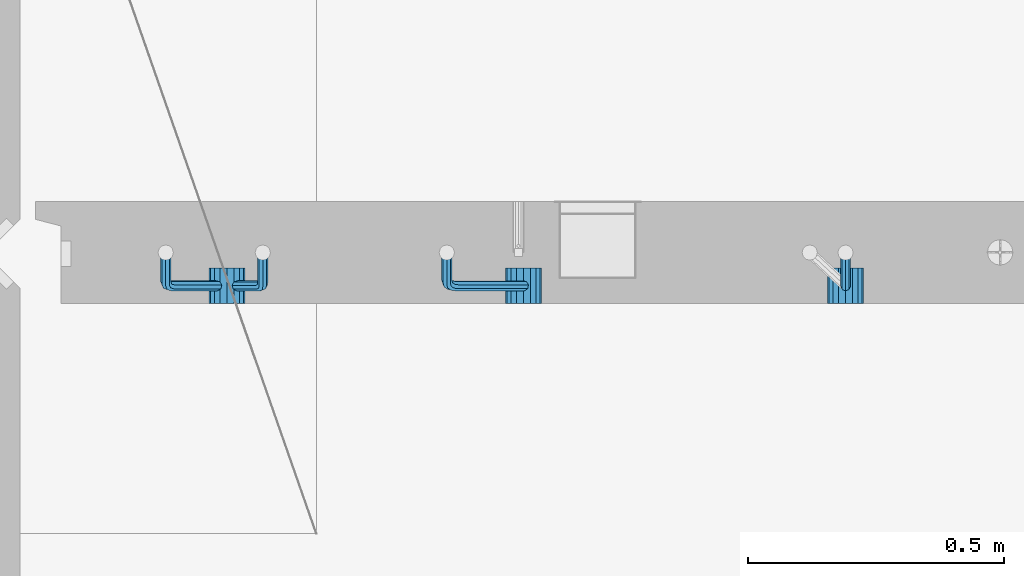
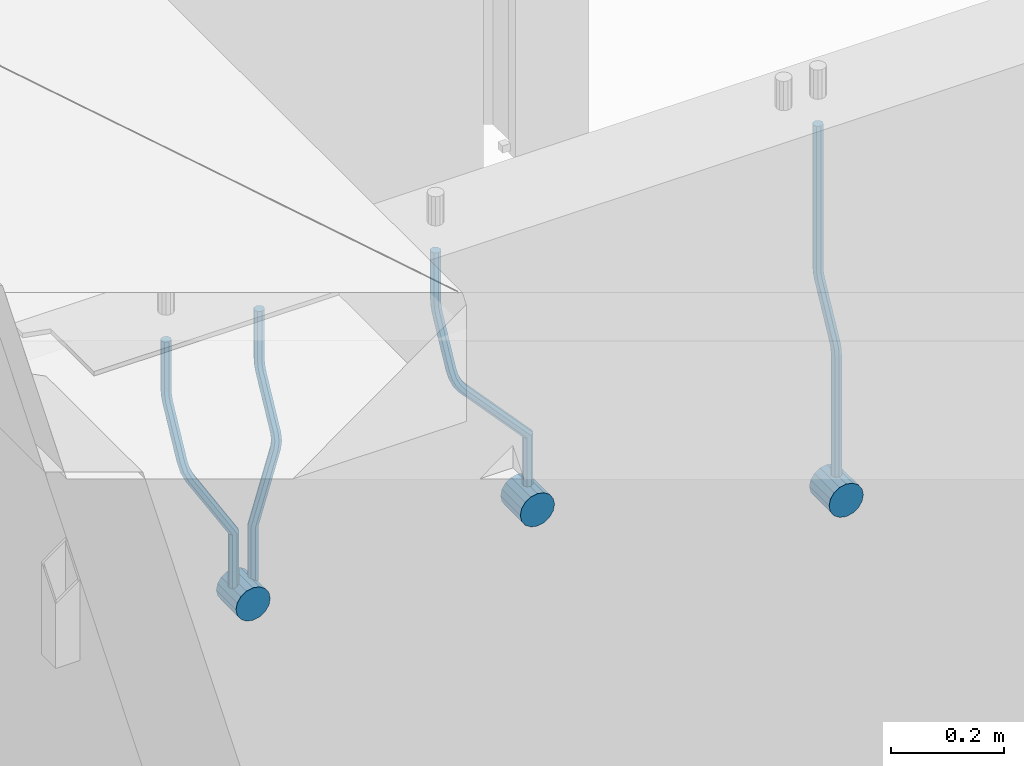
# One storey, part 148 of 334: 7 beams, 1 element without a shape of its own.
"""IFC2X3 building model written with IfcOpenShell, lengths in millimetres."""

import ifcopenshell
import ifcopenshell.guid

model = None  # the IFC model being written
_history = None  # IfcOwnerHistory: only IFC2X3 demands one
_inside = {}  # id of a spatial element -> (the spatial element, [elements in it])
_under = {}  # id of a project, library or spatial element -> (it, [spatial elements below it])
_declared = {}  # id of a project -> (the project, [libraries it declares])
_typed = {}  # id of a type object -> (the type object, [elements of that type])
_made_of = {}  # id of a material, layer set ... -> (it, [elements and type objects made of it])


def new_model(schema):
    """Start an empty IFC model of exactly this schema.

    Asked for "IFC4X3", IfcOpenShell would pick the latest addendum, in which some entities
    have other attributes; the version numbers below select the first issue.
    IFC2X3 requires an IfcOwnerHistory on every rooted entity: one is made here for all.
    """
    global model, _history
    if schema == "IFC4X3":
        model = ifcopenshell.file(schema_version=(4, 3, 0, 0))
    else:
        model = ifcopenshell.file(schema=schema)
    _inside.clear()
    _under.clear()
    _declared.clear()
    _typed.clear()
    _made_of.clear()
    _history = None
    if model.schema == "IFC2X3":
        org = make("IfcOrganization", Name="unknown")
        user = make(
            "IfcPersonAndOrganization",
            ThePerson=make("IfcPerson", FamilyName="unknown"),
            TheOrganization=org,
        )
        app = make(
            "IfcApplication",
            ApplicationDeveloper=org,
            Version="unknown",
            ApplicationFullName="unknown",
            ApplicationIdentifier="unknown",
        )
        _history = make(
            "IfcOwnerHistory",
            OwningUser=user,
            OwningApplication=app,
            ChangeAction="ADDED",
            CreationDate=0,
        )
    return model


def make(cls, **values):
    """One entity of the class cls with the attributes given. An attribute that is None is left unset."""
    return model.create_entity(
        cls, **{name: value for name, value in values.items() if value is not None}
    )


def rooted(cls, **values):
    """An entity with a GlobalId (a new one), such as an element, a storey or a relation."""
    return make(cls, GlobalId=ifcopenshell.guid.new(), OwnerHistory=_history, **values)


def si_unit(unit_type, name, prefix=None):
    """IfcSIUnit, for example si_unit("LENGTHUNIT", "METRE", prefix="MILLI")."""
    return make("IfcSIUnit", UnitType=unit_type, Prefix=prefix, Name=name)


def assignment(units):
    """IfcUnitAssignment: the units of a project."""
    return None if units is None else make("IfcUnitAssignment", Units=units)


def point(xyz):
    """IfcCartesianPoint."""
    return None if xyz is None else make("IfcCartesianPoint", Coordinates=xyz)


def direction(xyz):
    """IfcDirection."""
    return None if xyz is None else make("IfcDirection", DirectionRatios=xyz)


def frame(location, z_axis=None, x_axis=None):
    """IfcAxis2Placement3D, a coordinate frame: its origin and axes. An axis left out is left unset."""
    return make(
        "IfcAxis2Placement3D",
        Location=point(location),
        Axis=direction(z_axis),
        RefDirection=direction(x_axis),
    )


def origin_with_axes():
    """The frame at (0, 0, 0) with the z axis (0, 0, 1) and the x axis (1, 0, 0) written out."""
    return frame((0.0, 0.0, 0.0), z_axis=(0.0, 0.0, 1.0), x_axis=(1.0, 0.0, 0.0))


def place(relative_to, where):
    """IfcLocalPlacement: puts the frame where relative to a parent placement (None: the world)."""
    return make(
        "IfcLocalPlacement", PlacementRelTo=relative_to, RelativePlacement=where
    )


def context(
    kind, dimensions, precision=None, world=None, true_north=None, identifier=None
):
    """IfcGeometricRepresentationContext, for example the 3D "Model" context."""
    return make(
        "IfcGeometricRepresentationContext",
        ContextIdentifier=identifier,
        ContextType=kind,
        CoordinateSpaceDimension=dimensions,
        Precision=precision,
        WorldCoordinateSystem=world,
        TrueNorth=true_north,
    )


def subcontext(parent, identifier, kind, view, scale=None):
    """IfcGeometricRepresentationSubContext, for example "Body" below "Model"."""
    return make(
        "IfcGeometricRepresentationSubContext",
        ContextIdentifier=identifier,
        ContextType=kind,
        ParentContext=parent,
        TargetScale=scale,
        TargetView=view,
    )


def project(units=None, contexts=None):
    """IfcProject with its units and contexts."""
    return rooted(
        "IfcProject",
        Name="project",
        RepresentationContexts=contexts,
        UnitsInContext=assignment(units),
    )


def spatial(cls, under=None, at=None, **own):
    """A site, building, storey or space (cls), placed at a placement, below another one or the project."""
    s = rooted(cls, ObjectPlacement=at, **own)
    if under is not None:
        _under.setdefault(under.id(), (under, []))[1].append(s)
    return s


def faces_of(points, faces, orient=None, outer=None):
    """IfcFace entities. A face is a list of loops; a loop is a list of indices into points, from 0.

    orient and outer hold one flag for each loop. By default every Orientation is true, the
    first loop of a face is its IfcFaceOuterBound and the others are IfcFaceBound.
    """
    made = []
    for i, loops in enumerate(faces):
        bounds = []
        for j, loop in enumerate(loops):
            is_outer = j == 0 if outer is None else outer[i][j]
            bounds.append(
                make(
                    "IfcFaceOuterBound" if is_outer else "IfcFaceBound",
                    Bound=make("IfcPolyLoop", Polygon=[points[k] for k in loop]),
                    Orientation=True if orient is None else orient[i][j],
                )
            )
        made.append(make("IfcFace", Bounds=bounds))
    return made


def faceted_brep(points, faces, orient=None, outer=None, voids=None):
    """IfcFacetedBrep: a solid bounded by flat faces; with voids (closed shells), ...WithVoids."""
    shared = [point(p) for p in points]
    hull = make("IfcClosedShell", CfsFaces=faces_of(shared, faces, orient, outer))
    if voids is None:
        return make("IfcFacetedBrep", Outer=hull)
    return make(
        "IfcFacetedBrepWithVoids",
        Outer=hull,
        Voids=[
            make(cls, CfsFaces=faces_of(shared, fs, o, b)) for cls, fs, o, b in voids
        ],
    )


def shape(context_of_items, identifier, shape_type, items):
    """IfcShapeRepresentation: the items that make up one representation, for example the "Body"."""
    return make(
        "IfcShapeRepresentation",
        ContextOfItems=context_of_items,
        RepresentationIdentifier=identifier,
        RepresentationType=shape_type,
        Items=items,
    )


def material(Name=None, Category=None):
    """IfcMaterial."""
    return make("IfcMaterial", Name=Name, Category=Category)


def made_of(thing, what):
    """Note that an element or type object is made of a material, layer set ...; save() writes the relation."""
    if what is not None:
        _made_of.setdefault(what.id(), (what, []))[1].append(thing)
    return thing


def type_object(cls, material=None, **own):
    """A type object (cls), such as IfcWallType, which elements share."""
    return made_of(rooted(cls, **own), material)


def element(
    cls,
    number,
    at=None,
    inside=None,
    cuts=None,
    type_object=None,
    material=None,
    context=None,
    identifier="Body",
    shape_type=None,
    held_by="IfcProductDefinitionShape",
    body=None,
    shapes=None,
    **own,
):
    """One element of the class cls, such as IfcWall. Its Tag is "e" and its number.

    at: its placement. inside: the storey or other place that contains it. cuts: it is an
    opening in that element (IfcRelVoidsElement). A single representation is given by context,
    identifier, shape_type and body (its items); several are given by shapes. held_by: the class
    of the entity that holds the representations. save() writes the other relations.
    """
    e = rooted(cls, Tag="e%d" % number, ObjectPlacement=at, **own)
    if body is not None:
        shapes = [shape(context, identifier, shape_type, body)]
    if shapes is not None:
        e.Representation = make(held_by, Representations=shapes)
    if inside is not None:
        _inside.setdefault(inside.id(), (inside, []))[1].append(e)
    if cuts is not None:
        rooted(
            "IfcRelVoidsElement", RelatingBuildingElement=cuts, RelatedOpeningElement=e
        )
    if type_object is not None:
        _typed.setdefault(type_object.id(), (type_object, []))[1].append(e)
    return made_of(e, material)


def aggregate(whole, parts):
    """IfcRelAggregates: a whole, such as a stair, and the parts it consists of."""
    return rooted("IfcRelAggregates", RelatingObject=whole, RelatedObjects=parts)


def save(model, path):
    """Write the relations noted so far, then the file.

    IfcRelAggregates (storeys below a building ...), IfcRelContainedInSpatialStructure (elements
    in a storey), IfcRelDefinesByType, IfcRelAssociatesMaterial and IfcRelDeclares: one each for
    every whole, place, type object, material and project.
    """
    for whole, parts in _under.values():
        aggregate(whole, parts)
    for where, things in _inside.values():
        rooted(
            "IfcRelContainedInSpatialStructure",
            RelatedElements=things,
            RelatingStructure=where,
        )
    for kind, things in _typed.values():
        rooted("IfcRelDefinesByType", RelatedObjects=things, RelatingType=kind)
    for what, things in _made_of.values():
        rooted("IfcRelAssociatesMaterial", RelatedObjects=things, RelatingMaterial=what)
    for by, libraries in _declared.values():
        rooted("IfcRelDeclares", RelatingContext=by, RelatedDefinitions=libraries)
    model.write(path)


model = new_model("IFC2X3")

# Units and contexts
model_context = context("Model", 3, precision=1e-05, world=origin_with_axes())
body_context = subcontext(model_context, "Body", "Model", "MODEL_VIEW")
ifc_project = project(units=[si_unit("LENGTHUNIT", "METRE", prefix="MILLI"), si_unit("AREAUNIT", "SQUARE_METRE"), si_unit("VOLUMEUNIT", "CUBIC_METRE"), si_unit("MASSUNIT", "GRAM", prefix="KILO"), si_unit("TIMEUNIT", "SECOND"), si_unit("PLANEANGLEUNIT", "RADIAN"), si_unit("SOLIDANGLEUNIT", "STERADIAN"), si_unit("THERMODYNAMICTEMPERATUREUNIT", "DEGREE_CELSIUS"), si_unit("LUMINOUSINTENSITYUNIT", "LUMEN")], contexts=[model_context])

# Site, building, storey
site_placement = place(None, origin_with_axes())
site = spatial("IfcSite", under=ifc_project, at=site_placement, CompositionType="ELEMENT")
building_placement = place(site_placement, origin_with_axes())
building = spatial("IfcBuilding", under=site, at=building_placement, CompositionType="ELEMENT")
storey_placement = place(building_placement, origin_with_axes())
storey = spatial("IfcBuildingStorey", under=building, at=storey_placement, Name="3", CompositionType="ELEMENT", Elevation=0.0)

# Assembly, beams
assembly_placement = place(storey_placement, origin_with_axes())
assembly = element("IfcElementAssembly", 1, at=assembly_placement, inside=storey, AssemblyPlace="NOTDEFINED", PredefinedType="REINFORCEMENT_UNIT")
ifc_material = material()
beam_type_1 = type_object("IfcBeamType", Name="D20", PredefinedType="NOTDEFINED")
beam_1_placement = place(assembly_placement, frame((9615.0034031366, 16979.9000008034, 90407.5), z_axis=(-0.000415599999849952, -0.999999913638316, 0.0), x_axis=(0.0, 0.0, -1.0)))
beam_1 = element("IfcBeam", 2, at=beam_1_placement, type_object=beam_type_1, material=ifc_material, Name="JM20", ObjectType="D20", context=body_context, shape_type="Brep", body=[
    faceted_brep([(0.0, -10.0, 0.0), (-4.19531716033816e-08, -7.07106781186667, -7.07106781187031), (308.817759199839, -7.07106784567077, -7.07106781098628), (308.817759199388, -10.0000000315576, 1.18961906991899e-09), (0.0, 0.0, -10.0), (308.817759200625, -3.38059180648997e-08, -9.99999999911961), (4.196772351861e-08, 7.07106781186303, -7.07106781186667), (308.817759201396, 7.07106777806075, -7.07106781098992), (0.0, 10.0, 0.0), (308.817759201687, 9.99999996619408, 8.76752892509103e-10), (4.196772351861e-08, 7.07106781185939, 7.07106781185939), (308.817759201353, 7.07106777805893, 7.07106781273978), (0.0, 0.0, 10.0), (308.817759200567, -3.38059180648997e-08, 10.0000000008768), (-4.19531716033816e-08, -7.07106781187031, 7.07106781185939), (308.817759199781, -7.07106784567259, 7.07106781274342), (323.108969574154, 0.000717635259206872, -8.27316123493802), (322.412036484602, -7.07038517474393, -5.42844102338131), (320.72809124495, -9.99940192615759, 1.43915193649809), (319.043566138222, -7.07055433041933, 8.30667482965873), (318.345233125816, 0.000478413006931078, 11.1512258851908), (319.042166215368, 7.07158122300643, 8.30650567364501), (320.726111455049, 10.0005979744237, 1.4389127137656), (322.410636561748, 7.07175037869092, -5.42861017940231), (335.221090258594, 7.07375888522984, -0.59577927861028), (336.577559329642, 0.00282932867594354, -3.19204402394098), (331.949003496353, 10.0023575726736, 5.67282516818887), (328.678043090971, 7.07309199865631, 11.9417058486688), (327.324293285914, 0.00188620863991673, 14.5386374811205), (328.680762356948, -7.06904334791398, 11.9423727357971), (331.952849119407, -9.99764203791528, 5.67376828873239), (335.223809524556, -7.06837646134409, -0.59511239150379), (438.031978881656, -7.04607830785426, 53.0582885393342), (434.761018476231, -9.97534387865016, 59.3271692200688), (439.385728686641, 0.0251274821457628, 50.4613569068679), (438.02925961549, 7.0960570387233, 53.0576216521513), (434.757172853177, 10.0246557262235, 59.326226098925), (431.486212447766, 7.0953901522571, 65.5951067794085), (430.132462642781, 0.0241843622607121, 68.1920384118748), (431.488931713931, -7.04674519431865, 65.5957736665914), (448.364788846782, 0.0265352911246737, 53.8487685030559), (447.667855771331, -7.04456751813632, 56.6934887198913), (445.983910537514, -9.97358426776555, 63.5610816819462), (444.29938542498, -7.04473667025195, 70.428604572935), (443.601052398531, 0.0262960739091795, 73.2731556232175), (444.297985473939, 7.09739888316835, 70.4284354063821), (445.981930707741, 10.0264156328012, 63.5608424443053), (447.666455820276, 7.09756803528398, 56.6933195533311), (457.892262743961, 7.0980815803614, 57.9289265681182), (457.892262772089, 0.0270137655697908, 54.999994387068), (457.892262732348, 10.0270137755506, 64.9999943770345), (457.892262744092, 7.09808159448221, 72.0710621918224), (457.89226277222, 0.0270137855477515, 74.9999943870425), (457.89226280032, -7.04405402924385, 72.0710622060069), (457.892262811918, -9.97298622770904, 64.9999943967923), (457.892262800189, -7.04405404336103, 57.9289265822954), (717.500000028129, -7.04405301280349, 57.928926581666), (717.500000039799, -9.97298519384276, 64.9999943964685), (717.499999999956, 0.0270147961218754, 54.999994386435), (717.499999971798, 7.09808261092803, 57.9289265674743), (717.499999960128, 10.0270148061572, 64.9999943763978), (717.499999971813, 7.09808262511979, 72.071062191204), (717.499999999985, 0.0270148161926045, 74.999994386435), (717.500000028143, -7.04405299861173, 72.0710622053957)], [[[0, 1, 2, 3]], [[1, 4, 5, 2]], [[4, 6, 7, 5]], [[6, 8, 9, 7]], [[8, 10, 11, 9]], [[10, 12, 13, 11]], [[12, 14, 15, 13]], [[14, 0, 3, 15]], [[14, 12, 10, 8, 6, 4, 1, 0]], [[2, 5, 16, 17]], [[3, 2, 17, 18]], [[15, 3, 18, 19]], [[13, 15, 19, 20]], [[11, 13, 20, 21]], [[9, 11, 21, 22]], [[7, 9, 22, 23]], [[5, 7, 23, 16]], [[23, 24, 25, 16]], [[22, 26, 24, 23]], [[21, 27, 26, 22]], [[20, 28, 27, 21]], [[19, 29, 28, 20]], [[18, 30, 29, 19]], [[17, 31, 30, 18]], [[16, 25, 31, 17]], [[30, 31, 32, 33]], [[31, 25, 34, 32]], [[25, 24, 35, 34]], [[24, 26, 36, 35]], [[26, 27, 37, 36]], [[27, 28, 38, 37]], [[28, 29, 39, 38]], [[29, 30, 33, 39]], [[32, 34, 40, 41]], [[33, 32, 41, 42]], [[39, 33, 42, 43]], [[38, 39, 43, 44]], [[37, 38, 44, 45]], [[36, 37, 45, 46]], [[35, 36, 46, 47]], [[34, 35, 47, 40]], [[47, 48, 49, 40]], [[46, 50, 48, 47]], [[45, 51, 50, 46]], [[44, 52, 51, 45]], [[43, 53, 52, 44]], [[42, 54, 53, 43]], [[41, 55, 54, 42]], [[40, 49, 55, 41]], [[54, 55, 56, 57]], [[55, 49, 58, 56]], [[49, 48, 59, 58]], [[48, 50, 60, 59]], [[50, 51, 61, 60]], [[51, 52, 62, 61]], [[52, 53, 63, 62]], [[53, 54, 57, 63]], [[58, 59, 60, 61, 62, 63, 57, 56]]]),
])
beam_2_placement = place(assembly_placement, frame((8835.00340324668, 16979.9000008034, 90407.5), z_axis=(-0.000415599999849952, -0.999999913638316, 0.0), x_axis=(0.0, 0.0, -1.0)))
beam_2 = element("IfcBeam", 3, at=beam_2_placement, type_object=beam_type_1, material=ifc_material, Name="JM20", ObjectType="D20", context=body_context, shape_type="Brep", body=[
    faceted_brep([(0.0, -10.0, 0.0), (-4.19531716033816e-08, -7.07106781186667, -7.07106781187031), (108.817745274035, -7.07106780534923, -7.07106781138282), (108.817745274282, -9.99999999387728, 6.25732354819775e-10), (0.0, 0.0, -10.0), (108.817745273627, 6.5174390329048e-09, -9.99999999951979), (4.196772351861e-08, 7.07106781186303, -7.07106781186667), (108.817745273191, 7.07106781838229, -7.07106781138646), (0.0, 10.0, 0.0), (108.817745272972, 10.0000000065156, 4.80213202536106e-10), (4.196772351861e-08, 7.07106781185939, 7.07106781185939), (108.817745273118, 7.07106781838047, 7.07106781234688), (0.0, 0.0, 10.0), (108.817745273511, 6.51562004350126e-09, 10.0000000004839), (-4.19531716033816e-08, -7.07106781187031, 7.07106781185939), (108.817745273947, -7.07106780535105, 7.07106781234688), (123.108954183059, 0.000717681035894202, -8.27316159443217), (122.412021172189, -7.07038512938016, -5.42844136475105), (120.72807610796, -9.99940188179062, 1.43915163770362), (119.043551170704, -7.07055428705462, 8.30667457294476), (118.345218222516, 0.000478455955089885, 11.1512256454189), (119.0421512334, 7.07158126637114, 8.30650541574869), (120.726096297614, 10.0005980187834, 1.43891241329038), (122.410621234856, 7.0717504240456, -5.42861052196531), (135.22107377628, 7.07375894905454, -0.595780608462519), (136.577542729705, 0.00282939387761871, -3.19204541917861), (131.948987323645, 10.0023576331841, 5.67282400158729), (128.678027238435, 7.07309205585807, 11.9417048475552), (127.324277576598, 0.00188626447015849, 14.5386365507547), (128.680746529979, -7.06904329070858, 11.9423717400241), (131.952832982774, -9.99764197422519, 5.67376712984333), (135.223793067897, -7.06837639751029, -0.595113715968182), (228.618473932263, -7.04811975626581, 48.1455814515648), (225.347513847039, -9.97738533437769, 54.4144622980784), (229.972223594217, 0.0230860351002775, 45.5486497482525), (228.615754640981, 7.0940155903063, 48.1449145588849), (225.343668188434, 10.0226142745032, 54.413519168902), (222.072708103209, 7.0933486972317, 60.6824000149136), (220.71895844127, 0.0221429058692593, 63.2793317182222), (222.075427394506, -7.04878664933858, 60.6830669075935), (242.359530626607, -5.11807977741773, 54.2178725378544), (240.589998539246, -7.8364579297413, 61.1502473240325), (237.467032239641, -4.88691414189452, 67.4847494116439), (234.820023031163, 2.00274883800921, 69.5107133886158), (234.199553008453, 8.79665987653607, 66.041357034137), (235.9690850958, 11.515038028856, 59.108982247948), (239.092051395462, 8.56549424101649, 52.7744801603476), (241.739060603926, 1.67583126110367, 50.7485161833647), (253.320593995435, 6.49475796966908, 54.0461912154642), (255.884193780192, 0.509358169847474, 58.0688258176233), (249.403367901468, 12.8559000820806, 55.7104792064529), (246.427173417251, 15.8665137298067, 62.0867724571763), (246.135424907392, 13.7630222690877, 69.4399248590198), (248.699024692221, 7.77762246929342, 73.462559461208), (252.616250786203, 1.41648035689104, 71.7982714702011), (255.592445270362, -1.59413329085874, 65.4219782194778), (263.775218458322, 14.0880763316163, 55.1735662778046), (268.092877162446, 9.37667043252804, 59.3853499298057), (258.711370403718, 19.6164132468075, 56.7142082202008), (255.867666511243, 22.72325639054, 63.1047886019151), (256.909909953785, 21.588659185405, 70.6017921067651), (261.227568657952, 16.8772532863513, 74.8135757587734), (266.291416712571, 11.348916371182, 73.2729338163554), (269.135120604697, 8.24207322799703, 66.8823534341354), (411.777331932535, 141.004054536572, 59.330645583992), (412.819575375106, 139.86945733149, 66.8276490888165), (407.459673228295, 145.71546043558, 55.1188619320019), (402.395825173633, 151.243797350722, 56.6595038743981), (399.552121281173, 154.350640494475, 63.0500842560868), (400.594364723744, 153.216043289394, 70.547087760915), (404.912023427984, 148.504637390388, 74.7588714129015), (409.975871482646, 142.976300475242, 73.2182294705053), (412.588360762704, 141.747027069805, 59.3303368045817), (413.18825896435, 140.207203377095, 66.8275087215443), (410.103187350978, 148.137147940774, 55.1178554785947), (407.188519608899, 155.634319848998, 56.6576791731022), (405.551730369989, 159.846801170075, 63.047800051525), (406.151628571635, 158.306977477367, 70.5449719684912), (408.636801983361, 151.916856606398, 74.7574532944818), (411.551469725426, 144.419684698174, 73.2176295999743), (413.688258959737, 141.747027073105, 59.3303368045781), (413.68825896435, 140.207203378595, 66.8275087215443), (413.688258940572, 148.137147951529, 55.1178554785911), (413.688258918075, 155.634319868494, 56.6576791730986), (413.688258905444, 159.846801194481, 63.0478000515213), (413.688258910042, 158.306977499973, 70.5449719684912), (413.688258929222, 151.916856621549, 74.7574532944782), (413.688258951704, 144.419684704584, 73.2176295999707), (517.499999574822, 141.74702738449, 59.3303368045817), (517.499999579435, 140.207203689981, 66.8275087215443), (517.499999555657, 148.137148262915, 55.1178554785947), (517.499999533175, 155.634320179879, 56.6576791731022), (517.499999520529, 159.846801505866, 63.047800051525), (517.499999525127, 158.306977811359, 70.5449719684912), (517.499999544307, 151.916856932934, 74.7574532944818), (517.499999566789, 144.41968501597, 73.2176295999743)], [[[0, 1, 2, 3]], [[1, 4, 5, 2]], [[4, 6, 7, 5]], [[6, 8, 9, 7]], [[8, 10, 11, 9]], [[10, 12, 13, 11]], [[12, 14, 15, 13]], [[14, 0, 3, 15]], [[14, 12, 10, 8, 6, 4, 1, 0]], [[2, 5, 16, 17]], [[3, 2, 17, 18]], [[15, 3, 18, 19]], [[13, 15, 19, 20]], [[11, 13, 20, 21]], [[9, 11, 21, 22]], [[7, 9, 22, 23]], [[5, 7, 23, 16]], [[23, 24, 25, 16]], [[22, 26, 24, 23]], [[21, 27, 26, 22]], [[20, 28, 27, 21]], [[19, 29, 28, 20]], [[18, 30, 29, 19]], [[17, 31, 30, 18]], [[16, 25, 31, 17]], [[30, 31, 32, 33]], [[31, 25, 34, 32]], [[25, 24, 35, 34]], [[24, 26, 36, 35]], [[26, 27, 37, 36]], [[27, 28, 38, 37]], [[28, 29, 39, 38]], [[29, 30, 33, 39]], [[33, 32, 40, 41]], [[39, 33, 41, 42]], [[38, 39, 42, 43]], [[37, 38, 43, 44]], [[36, 37, 44, 45]], [[35, 36, 45, 46]], [[34, 35, 46, 47]], [[32, 34, 47, 40]], [[47, 48, 49, 40]], [[46, 50, 48, 47]], [[45, 51, 50, 46]], [[44, 52, 51, 45]], [[43, 53, 52, 44]], [[42, 54, 53, 43]], [[41, 55, 54, 42]], [[40, 49, 55, 41]], [[48, 56, 57, 49]], [[50, 58, 56, 48]], [[51, 59, 58, 50]], [[52, 60, 59, 51]], [[53, 61, 60, 52]], [[54, 62, 61, 53]], [[55, 63, 62, 54]], [[49, 57, 63, 55]], [[63, 57, 64, 65]], [[57, 56, 66, 64]], [[56, 58, 67, 66]], [[58, 59, 68, 67]], [[59, 60, 69, 68]], [[60, 61, 70, 69]], [[61, 62, 71, 70]], [[62, 63, 65, 71]], [[65, 64, 72, 73]], [[64, 66, 74, 72]], [[66, 67, 75, 74]], [[67, 68, 76, 75]], [[68, 69, 77, 76]], [[69, 70, 78, 77]], [[70, 71, 79, 78]], [[71, 65, 73, 79]], [[73, 72, 80, 81]], [[72, 74, 82, 80]], [[74, 75, 83, 82]], [[75, 76, 84, 83]], [[76, 77, 85, 84]], [[77, 78, 86, 85]], [[78, 79, 87, 86]], [[79, 73, 81, 87]], [[81, 80, 88, 89]], [[80, 82, 90, 88]], [[82, 83, 91, 90]], [[83, 84, 92, 91]], [[84, 85, 93, 92]], [[85, 86, 94, 93]], [[86, 87, 95, 94]], [[87, 81, 89, 95]], [[90, 91, 92, 93, 94, 95, 89, 88]]]),
])
beam_3_placement = place(assembly_placement, frame((8475.00340324668, 16979.9000008034, 90407.5), z_axis=(-0.000415599999849952, -0.999999913638316, 0.0), x_axis=(0.0, 0.0, -1.0)))
beam_3 = element("IfcBeam", 4, at=beam_3_placement, type_object=beam_type_1, material=ifc_material, Name="JM20", ObjectType="D20", context=body_context, shape_type="Brep", body=[
    faceted_brep([(0.0, -10.0, 0.0), (-4.19531716033816e-08, -7.07106781186667, -7.07106781187031), (108.817745274035, -7.07106780534923, -7.07106781138282), (108.817745274282, -9.99999999387728, 6.25732354819775e-10), (0.0, 0.0, -10.0), (108.817745273627, 6.5174390329048e-09, -9.99999999951979), (4.196772351861e-08, 7.07106781186303, -7.07106781186667), (108.817745273191, 7.07106781838229, -7.07106781138646), (0.0, 10.0, 0.0), (108.817745272972, 10.0000000065156, 4.80213202536106e-10), (4.196772351861e-08, 7.07106781185939, 7.07106781185939), (108.817745273118, 7.07106781838047, 7.07106781234688), (0.0, 0.0, 10.0), (108.817745273511, 6.51562004350126e-09, 10.0000000004839), (-4.19531716033816e-08, -7.07106781187031, 7.07106781185939), (108.817745273947, -7.07106780535105, 7.07106781234688), (123.108954183059, 0.000717681035894202, -8.27316159443217), (122.412021172189, -7.07038512938016, -5.42844136475105), (120.72807610796, -9.99940188179062, 1.43915163770362), (119.043551170704, -7.07055428705462, 8.30667457294476), (118.345218222516, 0.000478455955089885, 11.1512256454189), (119.0421512334, 7.07158126637114, 8.30650541574869), (120.726096297614, 10.0005980187834, 1.43891241329038), (122.410621234856, 7.0717504240456, -5.42861052196531), (135.22107377628, 7.07375894905454, -0.595780608462519), (136.577542729705, 0.00282939387761871, -3.19204541917861), (131.948987323645, 10.0023576331841, 5.67282400158729), (128.678027238435, 7.07309205585807, 11.9417048475552), (127.324277576598, 0.00188626447015849, 14.5386365507547), (128.680746529979, -7.06904329070858, 11.9423717400241), (131.952832982774, -9.99764197422519, 5.67376712984333), (135.223793067897, -7.06837639751029, -0.595113715968182), (236.184987141853, -7.04647863304126, 52.0943835719445), (232.914027056744, -9.97574421112949, 58.3632644184945), (237.538736803792, 0.0247271583230031, 49.4974518686358), (236.182267850556, 7.09565671352902, 52.093716679261), (232.910181397994, 10.0242553977168, 58.3623212892744), (229.639221312784, 7.0949898204417, 64.631202135286), (228.28547165083, 0.0237840290774329, 67.2281338385947), (229.64194060408, -7.04714552612859, 64.6318690279659), (248.6361426574, 6.07228546495571, 56.8411920703111), (248.347225361111, -0.863437898962729, 53.6176983169717), (246.616285773896, -7.90364889308694, 56.0708434545886), (244.457284830249, -10.9242873990424, 62.7636083320067), (243.134936001807, -8.15590434705155, 69.7754620538217), (243.423853298023, -1.22018098313129, 72.9989558071647), (245.154792885252, 5.82003001100384, 70.5458106695442), (247.313793828915, 8.84066851695206, 63.8530457921224), (262.262810178814, 5.37582167724941, 65.733133839356), (261.561593060862, 3.07645584421334, 58.4667829613572), (261.257873569193, 2.08769693226714, 72.5710415482208), (259.135461468584, -4.86177950991259, 74.9749524903455), (257.138854100602, -11.4016986008392, 71.5366882385752), (256.437636982591, -13.7010644331713, 64.2703373600561), (257.442573592241, -10.4129396888893, 57.4324296517152), (259.564985692865, -3.46346324671867, 55.0285187095906), (405.56030258059, -55.6424869289785, 57.4512270528103), (404.555365971013, -58.9306116739535, 64.2891347616751), (407.682714681185, -48.6930104868225, 55.0473161106529), (409.679322049255, -42.153091395905, 58.4855803623905), (410.380539167294, -39.8537255628671, 65.7519312403674), (409.375602557717, -43.1418503078439, 72.5898389492322), (407.253190457122, -50.09132675, 74.993749891386), (405.256583089053, -56.6312458409175, 71.5554856396557), (408.394915116543, -56.5080702894629, 57.4515867892878), (407.881249744809, -59.9462106727442, 64.2895568446584), (409.479769216079, -49.2417629119063, 55.0475441721828), (410.500319225088, -42.4037928534744, 58.4856845539216), (410.858740789379, -39.9997502352981, 65.751991928224), (410.345075417616, -43.4378906185757, 72.5899619835945), (409.26022131808, -50.7041979961323, 74.9940046006996), (408.239671309086, -57.5421680545642, 71.5558642189608), (411.358740838899, -56.5080702805735, 57.4515867892915), (411.358740849202, -59.9462106623123, 64.2895568446584), (411.358740817101, -49.2417629062693, 55.0475441721828), (411.358740796582, -42.4037928508988, 58.4856845539216), (411.358740789379, -39.9997502337974, 65.751991928224), (411.358740799667, -43.4378906155343, 72.5899619835945), (411.358740821452, -50.7041979898386, 74.9940046006996), (411.35874084197, -57.5421680452091, 71.5558642189608), (527.500000169515, -56.5080699322043, 57.4515867892878), (527.500000179818, -59.9462103139449, 64.2895568446584), (527.500000147716, -49.2417625579019, 55.0475441721828), (527.500000127198, -42.4037925025295, 58.4856845539216), (527.500000119981, -39.9997498854282, 65.751991928224), (527.500000130283, -43.4378902671669, 72.5899619835945), (527.500000152068, -50.7041976414694, 74.9940046006996), (527.500000172586, -57.5421676968399, 71.5558642189608)], [[[0, 1, 2, 3]], [[1, 4, 5, 2]], [[4, 6, 7, 5]], [[6, 8, 9, 7]], [[8, 10, 11, 9]], [[10, 12, 13, 11]], [[12, 14, 15, 13]], [[14, 0, 3, 15]], [[14, 12, 10, 8, 6, 4, 1, 0]], [[2, 5, 16, 17]], [[3, 2, 17, 18]], [[15, 3, 18, 19]], [[13, 15, 19, 20]], [[11, 13, 20, 21]], [[9, 11, 21, 22]], [[7, 9, 22, 23]], [[5, 7, 23, 16]], [[23, 24, 25, 16]], [[22, 26, 24, 23]], [[21, 27, 26, 22]], [[20, 28, 27, 21]], [[19, 29, 28, 20]], [[18, 30, 29, 19]], [[17, 31, 30, 18]], [[16, 25, 31, 17]], [[30, 31, 32, 33]], [[31, 25, 34, 32]], [[25, 24, 35, 34]], [[24, 26, 36, 35]], [[26, 27, 37, 36]], [[27, 28, 38, 37]], [[28, 29, 39, 38]], [[29, 30, 33, 39]], [[34, 35, 40, 41]], [[32, 34, 41, 42]], [[33, 32, 42, 43]], [[39, 33, 43, 44]], [[38, 39, 44, 45]], [[37, 38, 45, 46]], [[36, 37, 46, 47]], [[35, 36, 47, 40]], [[47, 48, 49, 40]], [[46, 50, 48, 47]], [[45, 51, 50, 46]], [[44, 52, 51, 45]], [[43, 53, 52, 44]], [[42, 54, 53, 43]], [[41, 55, 54, 42]], [[40, 49, 55, 41]], [[53, 54, 56, 57]], [[54, 55, 58, 56]], [[55, 49, 59, 58]], [[49, 48, 60, 59]], [[48, 50, 61, 60]], [[50, 51, 62, 61]], [[51, 52, 63, 62]], [[52, 53, 57, 63]], [[57, 56, 64, 65]], [[56, 58, 66, 64]], [[58, 59, 67, 66]], [[59, 60, 68, 67]], [[60, 61, 69, 68]], [[61, 62, 70, 69]], [[62, 63, 71, 70]], [[63, 57, 65, 71]], [[65, 64, 72, 73]], [[64, 66, 74, 72]], [[66, 67, 75, 74]], [[67, 68, 76, 75]], [[68, 69, 77, 76]], [[69, 70, 78, 77]], [[70, 71, 79, 78]], [[71, 65, 73, 79]], [[73, 72, 80, 81]], [[72, 74, 82, 80]], [[74, 75, 83, 82]], [[75, 76, 84, 83]], [[76, 77, 85, 84]], [[77, 78, 86, 85]], [[78, 79, 87, 86]], [[79, 73, 81, 87]], [[82, 83, 84, 85, 86, 87, 81, 80]]]),
])
beam_4_placement = place(assembly_placement, frame((8285.00340324668, 16979.9000008034, 90407.5), z_axis=(-0.000415599999849952, -0.999999913638316, 0.0), x_axis=(0.0, 0.0, -1.0)))
beam_4 = element("IfcBeam", 5, at=beam_4_placement, type_object=beam_type_1, material=ifc_material, Name="JM20", ObjectType="D20", context=body_context, shape_type="Brep", body=[
    faceted_brep([(0.0, -10.0, 0.0), (-4.19531716033816e-08, -7.07106781186667, -7.07106781187031), (108.817745274035, -7.07106780534923, -7.07106781138282), (108.817745274282, -9.99999999387728, 6.25732354819775e-10), (0.0, 0.0, -10.0), (108.817745273627, 6.5174390329048e-09, -9.99999999951979), (4.196772351861e-08, 7.07106781186303, -7.07106781186667), (108.817745273191, 7.07106781838229, -7.07106781138646), (0.0, 10.0, 0.0), (108.817745272972, 10.0000000065156, 4.80213202536106e-10), (4.196772351861e-08, 7.07106781185939, 7.07106781185939), (108.817745273118, 7.07106781838047, 7.07106781234688), (0.0, 0.0, 10.0), (108.817745273511, 6.51562004350126e-09, 10.0000000004839), (-4.19531716033816e-08, -7.07106781187031, 7.07106781185939), (108.817745273947, -7.07106780535105, 7.07106781234688), (123.108954183059, 0.000717681035894202, -8.27316159443217), (122.412021172189, -7.07038512938016, -5.42844136475105), (120.72807610796, -9.99940188179062, 1.43915163770362), (119.043551170704, -7.07055428705462, 8.30667457294476), (118.345218222516, 0.000478455955089885, 11.1512256454189), (119.0421512334, 7.07158126637114, 8.30650541574869), (120.726096297614, 10.0005980187834, 1.43891241329038), (122.410621234856, 7.0717504240456, -5.42861052196531), (135.22107377628, 7.07375894905454, -0.595780608462519), (136.577542729705, 0.00282939387761871, -3.19204541917861), (131.948987323645, 10.0023576331841, 5.67282400158729), (128.678027238435, 7.07309205585807, 11.9417048475552), (127.324277576598, 0.00188626447015849, 14.5386365507547), (128.680746529979, -7.06904329070858, 11.9423717400241), (131.952832982774, -9.99764197422519, 5.67376712984333), (135.223793067897, -7.06837639751029, -0.595113715968182), (232.402437428042, -7.04729904112355, 50.1203514230874), (229.131477342933, -9.97656461926999, 56.3892322695465), (233.756187089995, 0.0239067502407124, 47.5234197197824), (232.399718136745, 7.09483630544673, 50.1196845304112), (229.127631684183, 10.0234349896364, 56.3882891404246), (225.856671598973, 7.09416941235941, 62.6571699864289), (224.502921937034, 0.0229636209951423, 65.2541016897412), (225.859390890269, -7.04796593420906, 62.6578368791124), (249.189096393879, -4.47246690703469, 56.6819566015656), (248.077205390815, -7.070562329116, 63.794778990592), (245.438615273073, -4.04479441522199, 70.3110060036124), (242.818976346156, 2.83238302726022, 72.4135202319376), (241.752837564854, 9.53241272338892, 68.8706973556764), (242.864728567991, 12.130508145472, 61.7578749666827), (245.503318685674, 9.10474023159077, 55.2416479536478), (248.122957612577, 2.22756278908673, 53.1391337253044), (262.227655998417, 8.55574368060479, 55.0905560343417), (265.66954071114, 2.92161058118472, 58.9620696407692), (258.367889273839, 14.876528294435, 57.021495303452), (256.351239537093, 18.1813345207174, 63.6237694123665), (257.359032853405, 16.5342516931214, 71.0298557306051), (260.800917566128, 10.9001185936977, 74.9013693370434), (264.660684290735, 4.57933397990018, 72.9704300679259), (266.677334027001, 1.27452775464917, 66.3681559586585), (410.721160764631, 91.5081613346811, 58.9252530669619), (411.728954081002, 89.861078507096, 66.3313393852004), (407.279276051908, 97.1422944340902, 55.053739460498), (403.419509327403, 103.46307904791, 56.9846787295719), (401.402859590729, 106.767885274196, 63.5869528384683), (402.410652907114, 105.12080244661, 70.9930391567141), (405.852537619838, 99.4866693472013, 74.8645527631779), (409.712304344357, 93.1658847333838, 72.9336134941077), (411.611923002652, 92.0521714889783, 58.9250269763252), (412.155668410225, 90.1216833219078, 66.3312310778347), (409.754886469877, 98.6542099015223, 55.0531111083837), (407.672385626982, 106.060413996784, 56.9835992770786), (406.584321224072, 109.932329861462, 63.5856376951961), (407.12806663166, 108.001841694397, 70.9918417967092), (408.985103164436, 101.399803281851, 74.8637576646506), (411.06760400733, 93.9935991865859, 72.9332694959521), (412.655668404448, 92.0521714921069, 58.9250269763288), (412.655668410225, 90.1216833234084, 66.3312310778347), (412.655668384643, 98.6542099102207, 55.0531111083837), (412.655668362422, 106.06041401173, 56.9835992770822), (412.65566835081, 109.932329879672, 63.5856376951961), (412.655668356587, 108.001841710977, 70.9918417967056), (412.655668376392, 101.399803292861, 74.8637576646506), (412.655668398613, 93.9935991913499, 72.9332694959521), (527.499999723892, 92.0521718365853, 58.9250269763252), (527.499999729669, 90.1216836678886, 66.3312310778347), (527.499999704101, 98.6542102546991, 55.0531111083837), (527.499999681881, 106.060414356209, 56.9835992770786), (527.499999670254, 109.93233022415, 63.5856376951924), (527.499999676045, 108.001842055455, 70.9918417967056), (527.499999695836, 101.399803637341, 74.863757664647), (527.499999718057, 93.9935995358301, 72.9332694959521)], [[[0, 1, 2, 3]], [[1, 4, 5, 2]], [[4, 6, 7, 5]], [[6, 8, 9, 7]], [[8, 10, 11, 9]], [[10, 12, 13, 11]], [[12, 14, 15, 13]], [[14, 0, 3, 15]], [[14, 12, 10, 8, 6, 4, 1, 0]], [[2, 5, 16, 17]], [[3, 2, 17, 18]], [[15, 3, 18, 19]], [[13, 15, 19, 20]], [[11, 13, 20, 21]], [[9, 11, 21, 22]], [[7, 9, 22, 23]], [[5, 7, 23, 16]], [[23, 24, 25, 16]], [[22, 26, 24, 23]], [[21, 27, 26, 22]], [[20, 28, 27, 21]], [[19, 29, 28, 20]], [[18, 30, 29, 19]], [[17, 31, 30, 18]], [[16, 25, 31, 17]], [[30, 31, 32, 33]], [[31, 25, 34, 32]], [[25, 24, 35, 34]], [[24, 26, 36, 35]], [[26, 27, 37, 36]], [[27, 28, 38, 37]], [[28, 29, 39, 38]], [[29, 30, 33, 39]], [[33, 32, 40, 41]], [[39, 33, 41, 42]], [[38, 39, 42, 43]], [[37, 38, 43, 44]], [[36, 37, 44, 45]], [[35, 36, 45, 46]], [[34, 35, 46, 47]], [[32, 34, 47, 40]], [[47, 48, 49, 40]], [[46, 50, 48, 47]], [[45, 51, 50, 46]], [[44, 52, 51, 45]], [[43, 53, 52, 44]], [[42, 54, 53, 43]], [[41, 55, 54, 42]], [[40, 49, 55, 41]], [[55, 49, 56, 57]], [[49, 48, 58, 56]], [[48, 50, 59, 58]], [[50, 51, 60, 59]], [[51, 52, 61, 60]], [[52, 53, 62, 61]], [[53, 54, 63, 62]], [[54, 55, 57, 63]], [[57, 56, 64, 65]], [[56, 58, 66, 64]], [[58, 59, 67, 66]], [[59, 60, 68, 67]], [[60, 61, 69, 68]], [[61, 62, 70, 69]], [[62, 63, 71, 70]], [[63, 57, 65, 71]], [[65, 64, 72, 73]], [[64, 66, 74, 72]], [[66, 67, 75, 74]], [[67, 68, 76, 75]], [[68, 69, 77, 76]], [[69, 70, 78, 77]], [[70, 71, 79, 78]], [[71, 65, 73, 79]], [[73, 72, 80, 81]], [[72, 74, 82, 80]], [[74, 75, 83, 82]], [[75, 76, 84, 83]], [[76, 77, 85, 84]], [[77, 78, 86, 85]], [[78, 79, 87, 86]], [[79, 73, 81, 87]], [[82, 83, 84, 85, 86, 87, 81, 80]]]),
])
beam_type_2 = type_object("IfcBeamType", Name="D70", PredefinedType="NOTDEFINED")
beam_5_placement = place(assembly_placement, frame((9615.00340323833, 16879.9000008034, 89654.9999989631), z_axis=(0.0, 0.0, 1.0), x_axis=(0.0, 1.0, 0.0)))
beam_5 = element("IfcBeam", 6, at=beam_5_placement, type_object=beam_type_2, material=ifc_material, ObjectType="D70", context=body_context, shape_type="Brep", body=[
    faceted_brep([(0.0, -35.0, 0.0), (0.0, -32.3357836378964, -13.3939201327739), (70.0, -32.3357836378964, -13.3939201327739), (70.0, -35.0, 0.0), (0.0, -24.7487373415279, -24.7487373415352), (70.0, -24.7487373415279, -24.7487373415352), (0.0, -13.3939201327776, -32.3357836379), (70.0, -13.3939201327776, -32.3357836379), (0.0, 0.0, -35.0), (70.0, 0.0, -35.0), (0.0, 13.3939201327776, -32.3357836379), (70.0, 13.3939201327776, -32.3357836379), (0.0, 24.7487373415279, -24.7487373415352), (70.0, 24.7487373415279, -24.7487373415352), (0.0, 32.3357836378964, -13.3939201327739), (70.0, 32.3357836378964, -13.3939201327739), (0.0, 35.0, 0.0), (70.0, 35.0, 0.0), (0.0, 32.3357836378964, 13.3939201327739), (70.0, 32.3357836378964, 13.3939201327739), (0.0, 24.7487373415279, 24.7487373415352), (70.0, 24.7487373415279, 24.7487373415352), (0.0, 13.3939201327776, 32.3357836379), (70.0, 13.3939201327776, 32.3357836379), (0.0, 0.0, 35.0), (70.0, 0.0, 35.0), (0.0, -13.3939201327776, 32.3357836379), (70.0, -13.3939201327776, 32.3357836379), (0.0, -24.7487373415279, 24.7487373415352), (70.0, -24.7487373415279, 24.7487373415352), (0.0, -32.3357836378964, 13.3939201327739), (70.0, -32.3357836378964, 13.3939201327739)], [[[0, 1, 2, 3]], [[1, 4, 5, 2]], [[4, 6, 7, 5]], [[6, 8, 9, 7]], [[8, 10, 11, 9]], [[10, 12, 13, 11]], [[12, 14, 15, 13]], [[14, 16, 17, 15]], [[16, 18, 19, 17]], [[18, 20, 21, 19]], [[20, 22, 23, 21]], [[22, 24, 25, 23]], [[24, 26, 27, 25]], [[26, 28, 29, 27]], [[28, 30, 31, 29]], [[30, 0, 3, 31]], [[5, 7, 9, 11, 13, 15, 17, 19, 21, 23, 25, 27, 29, 31, 3, 2]], [[30, 28, 26, 24, 22, 20, 18, 16, 14, 12, 10, 8, 6, 4, 1, 0]]]),
])
beam_6_placement = place(assembly_placement, frame((8985.00340323833, 16879.9000008034, 89854.9999989631), z_axis=(0.0, 0.0, 1.0), x_axis=(0.0, 1.0, 0.0)))
beam_6 = element("IfcBeam", 7, at=beam_6_placement, type_object=beam_type_2, material=ifc_material, ObjectType="D70", context=body_context, shape_type="Brep", body=[
    faceted_brep([(0.0, -35.0, 0.0), (0.0, -32.3357836378964, -13.3939201327739), (70.0, -32.3357836378964, -13.3939201327739), (70.0, -35.0, 0.0), (0.0, -24.7487373415279, -24.7487373415352), (70.0, -24.7487373415279, -24.7487373415352), (0.0, -13.3939201327776, -32.3357836379), (70.0, -13.3939201327776, -32.3357836379), (0.0, 0.0, -35.0), (70.0, 0.0, -35.0), (0.0, 13.3939201327776, -32.3357836379), (70.0, 13.3939201327776, -32.3357836379), (0.0, 24.7487373415279, -24.7487373415352), (70.0, 24.7487373415279, -24.7487373415352), (0.0, 32.3357836378964, -13.3939201327739), (70.0, 32.3357836378964, -13.3939201327739), (0.0, 35.0, 0.0), (70.0, 35.0, 0.0), (0.0, 32.3357836378964, 13.3939201327739), (70.0, 32.3357836378964, 13.3939201327739), (0.0, 24.7487373415279, 24.7487373415352), (70.0, 24.7487373415279, 24.7487373415352), (0.0, 13.3939201327776, 32.3357836379), (70.0, 13.3939201327776, 32.3357836379), (0.0, 0.0, 35.0), (70.0, 0.0, 35.0), (0.0, -13.3939201327776, 32.3357836379), (70.0, -13.3939201327776, 32.3357836379), (0.0, -24.7487373415279, 24.7487373415352), (70.0, -24.7487373415279, 24.7487373415352), (0.0, -32.3357836378964, 13.3939201327739), (70.0, -32.3357836378964, 13.3939201327739)], [[[0, 1, 2, 3]], [[1, 4, 5, 2]], [[4, 6, 7, 5]], [[6, 8, 9, 7]], [[8, 10, 11, 9]], [[10, 12, 13, 11]], [[12, 14, 15, 13]], [[14, 16, 17, 15]], [[16, 18, 19, 17]], [[18, 20, 21, 19]], [[20, 22, 23, 21]], [[22, 24, 25, 23]], [[24, 26, 27, 25]], [[26, 28, 29, 27]], [[28, 30, 31, 29]], [[30, 0, 3, 31]], [[5, 7, 9, 11, 13, 15, 17, 19, 21, 23, 25, 27, 29, 31, 3, 2]], [[30, 28, 26, 24, 22, 20, 18, 16, 14, 12, 10, 8, 6, 4, 1, 0]]]),
])
beam_7_placement = place(assembly_placement, frame((8405.00340323833, 16879.9000008034, 89854.9999989631), z_axis=(0.0, 0.0, 1.0), x_axis=(0.0, 1.0, 0.0)))
beam_7 = element("IfcBeam", 8, at=beam_7_placement, type_object=beam_type_2, material=ifc_material, ObjectType="D70", context=body_context, shape_type="Brep", body=[
    faceted_brep([(0.0, -35.0, 0.0), (0.0, -32.3357836378964, -13.3939201327739), (70.0, -32.3357836378964, -13.3939201327739), (70.0, -35.0, 0.0), (0.0, -24.7487373415279, -24.7487373415352), (70.0, -24.7487373415279, -24.7487373415352), (0.0, -13.3939201327776, -32.3357836379), (70.0, -13.3939201327776, -32.3357836379), (0.0, 0.0, -35.0), (70.0, 0.0, -35.0), (0.0, 13.3939201327776, -32.3357836379), (70.0, 13.3939201327776, -32.3357836379), (0.0, 24.7487373415279, -24.7487373415352), (70.0, 24.7487373415279, -24.7487373415352), (0.0, 32.3357836378964, -13.3939201327739), (70.0, 32.3357836378964, -13.3939201327739), (0.0, 35.0, 0.0), (70.0, 35.0, 0.0), (0.0, 32.3357836378964, 13.3939201327739), (70.0, 32.3357836378964, 13.3939201327739), (0.0, 24.7487373415279, 24.7487373415352), (70.0, 24.7487373415279, 24.7487373415352), (0.0, 13.3939201327776, 32.3357836379), (70.0, 13.3939201327776, 32.3357836379), (0.0, 0.0, 35.0), (70.0, 0.0, 35.0), (0.0, -13.3939201327776, 32.3357836379), (70.0, -13.3939201327776, 32.3357836379), (0.0, -24.7487373415279, 24.7487373415352), (70.0, -24.7487373415279, 24.7487373415352), (0.0, -32.3357836378964, 13.3939201327739), (70.0, -32.3357836378964, 13.3939201327739)], [[[0, 1, 2, 3]], [[1, 4, 5, 2]], [[4, 6, 7, 5]], [[6, 8, 9, 7]], [[8, 10, 11, 9]], [[10, 12, 13, 11]], [[12, 14, 15, 13]], [[14, 16, 17, 15]], [[16, 18, 19, 17]], [[18, 20, 21, 19]], [[20, 22, 23, 21]], [[22, 24, 25, 23]], [[24, 26, 27, 25]], [[26, 28, 29, 27]], [[28, 30, 31, 29]], [[30, 0, 3, 31]], [[5, 7, 9, 11, 13, 15, 17, 19, 21, 23, 25, 27, 29, 31, 3, 2]], [[30, 28, 26, 24, 22, 20, 18, 16, 14, 12, 10, 8, 6, 4, 1, 0]]]),
])
aggregate(assembly, [beam_5, beam_1, beam_6, beam_2, beam_3, beam_7, beam_4])

save(model, "model.ifc")
